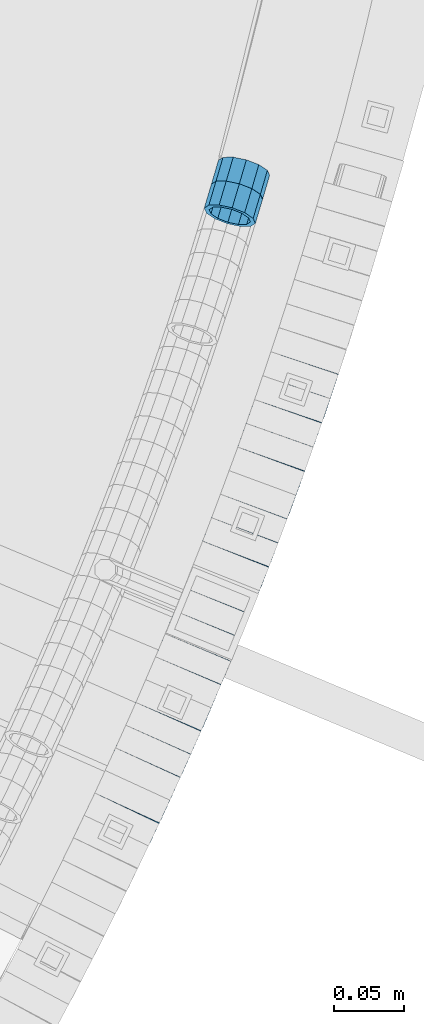
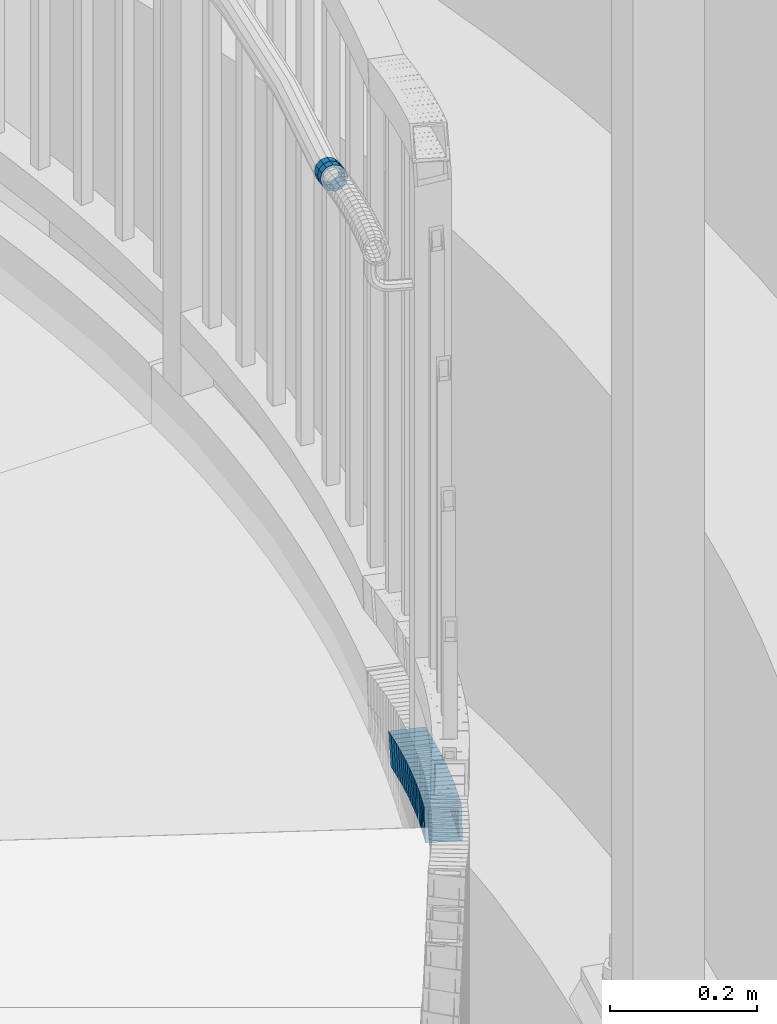
# One storey, part 798 of 975: 21 beams.
"""IFC2X3 building model written with IfcOpenShell, lengths in millimetres."""

from ifc_helpers import new_model, si_unit, frame, origin_with_axes, place, context, subcontext, project, spatial, faceted_brep, material, type_object, element, save


model = new_model("IFC2X3")

# Units and contexts
model_context = context("Model", 3, precision=1e-05, world=origin_with_axes())
body_context = subcontext(model_context, "Body", "Model", "MODEL_VIEW")
ifc_project = project(units=[si_unit("LENGTHUNIT", "METRE", prefix="MILLI"), si_unit("AREAUNIT", "SQUARE_METRE"), si_unit("VOLUMEUNIT", "CUBIC_METRE"), si_unit("MASSUNIT", "GRAM", prefix="KILO"), si_unit("TIMEUNIT", "SECOND"), si_unit("PLANEANGLEUNIT", "RADIAN"), si_unit("SOLIDANGLEUNIT", "STERADIAN"), si_unit("THERMODYNAMICTEMPERATUREUNIT", "DEGREE_CELSIUS"), si_unit("LUMINOUSINTENSITYUNIT", "LUMEN")], contexts=[model_context])

# Site, building, storey
site_placement = place(None, origin_with_axes())
site = spatial("IfcSite", under=ifc_project, at=site_placement, CompositionType="ELEMENT")
building_placement = place(site_placement, origin_with_axes())
building = spatial("IfcBuilding", under=site, at=building_placement, Name="Undefined", CompositionType="ELEMENT")
storey_placement = place(building_placement, origin_with_axes())
storey = spatial("IfcBuildingStorey", under=building, at=storey_placement, Name="Undefined", CompositionType="ELEMENT", Elevation=0.0)

# Beams
ifc_material = material()
beam_type_1 = type_object("IfcBeamType", PredefinedType="NOTDEFINED")
beam_1_placement = place(storey_placement, frame((37404.7874322749, 2603.67660607196, 3041.61300755579), z_axis=(-0.958287760646571, 0.285805122058686, -5.19926288689022e-11), x_axis=(0.271357223015151, 0.909844805051272, -0.313923061017693)))
element("IfcBeam", 1, at=beam_1_placement, inside=storey, type_object=beam_type_1, material=ifc_material, Name="WALL", context=body_context, shape_type="Brep", body=[
    faceted_brep([(-2.1246523829177e-07, -15.367000000002, 0.0), (-1.83998054126278e-07, -13.3082123799541, 7.68350000000009), (18.7944140637574, -13.3082123799568, 7.68350000002101), (18.7944140637537, -15.3669999999993, 2.91038304567337e-11), (-1.06232619145885e-07, -7.68349999999919, 13.3082123799559), (18.7944140637646, -7.68350000000282, 13.3082123799613), (-3.63797880709171e-12, 3.63797880709171e-12, 15.3670000000002), (18.7944140637646, -4.54747350886464e-12, 15.3669999999984), (1.06225343188271e-07, 7.68350000000646, 13.3082123799559), (18.7944140637683, 7.68349999999828, 13.3082123799613), (1.8399441614747e-07, 13.308212379965, 7.68350000000009), (18.7944140637665, 13.308212379955, 7.68350000001374), (2.12461600312963e-07, 15.3670000000093, 0.0), (18.7944140637592, 15.3670000000029, 2.91038304567337e-11), (1.8399441614747e-07, 13.308212379965, -7.68350000000009), (18.7944140637555, 13.3082123799613, -7.68349999995553), (1.06225343188271e-07, 7.68350000000646, -13.3082123799559), (18.7944140637519, 7.68350000000737, -13.3082123798958), (-3.63797880709171e-12, 3.63797880709171e-12, -15.3670000000002), (18.7944140637483, 6.3664629124105e-12, -15.3669999999474), (-1.06232619145885e-07, -7.68349999999919, -13.3082123799559), (18.7944140637501, -7.68349999999464, -13.3082123798958), (-1.83998054126278e-07, -13.3082123799541, -7.68350000000009), (18.7944140637483, -13.3082123799513, -7.68349999994098), (-2.63386027654633e-07, -19.0500000000029, 0.0), (-2.28097633225843e-07, -16.4977839420972, -9.52499999999964), (18.7944140637483, -16.497783942089, -9.52499999994325), (18.7944140637537, -19.0499999999984, 4.36557456851006e-11), (-1.31691194837913e-07, -9.52500000000146, -16.4977839420935), (18.7944140637483, -9.52499999999327, -16.4977839420244), (-3.63797880709171e-12, 3.63797880709171e-12, -19.0500000000002), (18.7944140637446, 8.18545231595635e-12, -19.0499999999302), (1.31687556859106e-07, 9.52500000000509, -16.4977839420935), (18.7944140637519, 9.52500000000873, -16.4977839420244), (2.28097633225843e-07, 16.4977839421044, -9.52499999999964), (18.7944140637555, 16.4977839420999, -9.52499999996508), (2.63382389675826e-07, 19.0500000000138, 0.0), (18.794414063761, 19.0500000000029, 2.91038304567337e-11), (2.28097633225843e-07, 16.4977839421044, 9.52499999999964), (18.7944140637665, 16.4977839420935, 9.52500000000873), (1.31687556859106e-07, 9.52500000000509, 16.4977839420935), (18.7944140637701, 9.524999999996, 16.4977839420899), (-3.63797880709171e-12, 3.63797880709171e-12, 19.0500000000002), (18.7944140637701, -5.45696821063757e-12, 19.0499999999884), (-1.31691194837913e-07, -9.52500000000146, 16.4977839420935), (18.7944140637665, -9.52500000000418, 16.4977839420972), (-2.28097633225843e-07, -16.4977839420972, 9.52499999999964), (18.7944140637574, -16.4977839420962, 9.52500000001601)], [[[0, 1, 2, 3]], [[1, 4, 5, 2]], [[4, 6, 7, 5]], [[6, 8, 9, 7]], [[8, 10, 11, 9]], [[10, 12, 13, 11]], [[12, 14, 15, 13]], [[14, 16, 17, 15]], [[16, 18, 19, 17]], [[18, 20, 21, 19]], [[20, 22, 23, 21]], [[22, 0, 3, 23]], [[24, 25, 26, 27]], [[25, 28, 29, 26]], [[28, 30, 31, 29]], [[30, 32, 33, 31]], [[32, 34, 35, 33]], [[34, 36, 37, 35]], [[36, 38, 39, 37]], [[38, 40, 41, 39]], [[40, 42, 43, 41]], [[42, 44, 45, 43]], [[44, 46, 47, 45]], [[46, 24, 27, 47]], [[29, 31, 33, 35, 37, 39, 41, 43, 45, 47, 27, 26], [5, 7, 9, 11, 13, 15, 17, 19, 21, 23, 3, 2]], [[46, 44, 42, 40, 38, 36, 34, 32, 30, 28, 25, 24], [22, 20, 18, 16, 14, 12, 10, 8, 6, 4, 1, 0]]]),
])
beam_2_placement = place(storey_placement, frame((37409.9416131534, 2620.84728896929, 3035.68573183975), z_axis=(-0.959811187688657, 0.280646546366937, -1.43101260619006e-10), x_axis=(0.266861250050846, 0.912665474173317, -0.30955905005878)))
element("IfcBeam", 2, at=beam_2_placement, inside=storey, type_object=beam_type_1, material=ifc_material, Name="WALL", context=body_context, shape_type="Brep", body=[
    faceted_brep([(-2.1246523829177e-07, -15.367000000002, 0.0), (-1.83998054126278e-07, -13.3082123799541, 7.68350000000009), (18.7395304103302, -13.3082123799504, 7.68350000005739), (18.7395304103338, -15.3669999999975, 4.36557456851006e-11), (-1.06232619145885e-07, -7.68349999999919, 13.3082123799559), (18.7395304103266, -7.68349999999191, 13.3082123800268), (-3.63797880709171e-12, 3.63797880709171e-12, 15.3670000000002), (18.7395304103284, 9.09494701772928e-12, 15.3670000000566), (1.06225343188271e-07, 7.68350000000646, 13.3082123799559), (18.7395304103284, 7.68350000000828, 13.308212380005), (1.8399441614747e-07, 13.308212379965, 7.68350000000009), (18.7395304103375, 13.3082123799613, 7.68350000002829), (2.12461600312963e-07, 15.3670000000093, 0.0), (18.7395304103429, 15.3670000000038, 1.45519152283669e-11), (1.8399441614747e-07, 13.308212379965, -7.68350000000009), (18.7395304103466, 13.3082123799559, -7.68350000000646), (1.06225343188271e-07, 7.68350000000646, -13.3082123799559), (18.7395304103484, 7.68349999999737, -13.3082123799686), (-3.63797880709171e-12, 3.63797880709171e-12, -15.3670000000002), (18.7395304103484, -3.63797880709171e-12, -15.3670000000129), (-1.06232619145885e-07, -7.68349999999919, -13.3082123799559), (18.7395304103466, -7.68350000000282, -13.3082123799541), (-1.83998054126278e-07, -13.3082123799541, -7.68350000000009), (18.7395304103411, -13.3082123799568, -7.68349999998463), (-2.63386027654633e-07, -19.0500000000029, 0.0), (-2.28097633225843e-07, -16.4977839420972, -9.52499999999964), (18.7395304103411, -16.4977839420953, -9.52499999997963), (18.7395304103356, -19.0499999999993, 4.36557456851006e-11), (-1.31691194837913e-07, -9.52500000000146, -16.4977839420935), (18.7395304103484, -9.52500000000509, -16.4977839420972), (-3.63797880709171e-12, 3.63797880709171e-12, -19.0500000000002), (18.7395304103557, -5.45696821063757e-12, -19.0500000000247), (1.31687556859106e-07, 9.52500000000509, -16.4977839420935), (18.739530410352, 9.52499999999691, -16.4977839421117), (2.28097633225843e-07, 16.4977839421044, -9.52499999999964), (18.7395304103484, 16.4977839420935, -9.52500000000146), (2.63382389675826e-07, 19.0500000000138, 0.0), (18.7395304103429, 19.0500000000029, 1.45519152283669e-11), (2.28097633225843e-07, 16.4977839421044, 9.52499999999964), (18.7395304103338, 16.4977839421008, 9.52500000003783), (1.31687556859106e-07, 9.52500000000509, 16.4977839420935), (18.7395304103302, 9.52500000000873, 16.4977839421481), (-3.63797880709171e-12, 3.63797880709171e-12, 19.0500000000002), (18.7395304103247, 1.09139364212751e-11, 19.0500000000684), (-1.31691194837913e-07, -9.52500000000146, 16.4977839420935), (18.7395304103247, -9.52499999999054, 16.4977839421699), (-2.28097633225843e-07, -16.4977839420972, 9.52499999999964), (18.7395304103284, -16.4977839420881, 9.52500000006694)], [[[0, 1, 2, 3]], [[1, 4, 5, 2]], [[4, 6, 7, 5]], [[6, 8, 9, 7]], [[8, 10, 11, 9]], [[10, 12, 13, 11]], [[12, 14, 15, 13]], [[14, 16, 17, 15]], [[16, 18, 19, 17]], [[18, 20, 21, 19]], [[20, 22, 23, 21]], [[22, 0, 3, 23]], [[24, 25, 26, 27]], [[25, 28, 29, 26]], [[28, 30, 31, 29]], [[30, 32, 33, 31]], [[32, 34, 35, 33]], [[34, 36, 37, 35]], [[36, 38, 39, 37]], [[38, 40, 41, 39]], [[40, 42, 43, 41]], [[42, 44, 45, 43]], [[44, 46, 47, 45]], [[46, 24, 27, 47]], [[29, 31, 33, 35, 37, 39, 41, 43, 45, 47, 27, 26], [5, 7, 9, 11, 13, 15, 17, 19, 21, 23, 3, 2]], [[46, 44, 42, 40, 38, 36, 34, 32, 30, 28, 25, 24], [22, 20, 18, 16, 14, 12, 10, 8, 6, 4, 1, 0]]]),
])
beam_type_2 = type_object("IfcBeamType", Name="HSS2X2X.188_TUBES", PredefinedType="NOTDEFINED")
beam_3_placement = place(storey_placement, frame((37328.2121095674, 2174.11265486473, 2258.91492460715), z_axis=(-0.906470607423007, 0.422268916542721, 1.90350419870811e-10), x_axis=(0.402071086044602, 0.863112598095702, -0.305574025033873)))
element("IfcBeam", 3, at=beam_3_placement, inside=storey, type_object=beam_type_2, material=ifc_material, Name="WALL", ObjectType="HSS2X2X.188_TUBES", context=body_context, shape_type="Brep", body=[
    faceted_brep([(0.0, 20.6374999999753, -20.6375000000298), (0.0, -20.6375000000153, -20.6375000000153), (18.6531498680506, -20.6374999999862, -20.6375000000007), (18.6531498680579, 20.637500000008, -20.6374999999935), (0.0, -20.6374999999825, 20.6375000000335), (18.6531498680379, -20.6374999999971, 20.6374999999789), (0.0, 20.6375000000116, 20.6375000000189), (18.6531498680451, 20.6374999999989, 20.6374999999898), (0.0, 25.3999999999724, -25.4000000000342), (0.0, 25.400000000016, 25.4000000000196), (18.653149868047, 25.399999999996, 25.3999999999869), (18.6531498680633, 25.4000000000087, -25.3999999999905), (0.0, -25.399999999976, 25.4000000000378), (18.6531498680361, -25.3999999999978, 25.3999999999796), (0.0, -25.400000000016, -25.4000000000196), (18.6531498680488, -25.3999999999851, -25.4000000000015)], [[[0, 1, 2, 3]], [[1, 4, 5, 2]], [[4, 6, 7, 5]], [[6, 0, 3, 7]], [[8, 9, 10, 11]], [[9, 12, 13, 10]], [[12, 14, 15, 13]], [[14, 8, 11, 15]], [[13, 15, 11, 10], [5, 7, 3, 2]], [[14, 12, 9, 8], [6, 4, 1, 0]]]),
])
for number, where, z_axis, x_axis, name in (
    (4, (37335.8795019804, 2190.38584330702, 2253.22561279411), (-0.91075353403974, 0.412950360496421, -1.40489646582865e-10), (0.393024484845579, 0.866807424659578, -0.306882131879483), "WALL"),
    (5, (37343.1795019804, 2206.48584330701, 2247.52561279411), (-0.91075353403974, 0.412950360496421, -1.40489646582865e-10), (0.393024484845579, 0.866807424659578, -0.306882131879483), "WALL"),
):
    element("IfcBeam", number, at=place(storey_placement, frame(where, z_axis=z_axis, x_axis=x_axis)), inside=storey, type_object=beam_type_2, material=ifc_material, Name=name, ObjectType="HSS2X2X.188_TUBES", context=body_context, shape_type="Brep", body=[
        faceted_brep([(0.0, 20.6374999999753, -20.6375000000298), (0.0, -20.6375000000153, -20.6375000000153), (18.5674446276062, -20.6375000000025, -20.6374999999898), (18.5674446275571, 20.6375000000053, -20.6374999999025), (0.0, -20.6374999999825, 20.6375000000335), (18.5674446276444, -20.6375000000135, 20.6374999999098), (0.0, 20.6375000000116, 20.6375000000189), (18.5674446275953, 20.6374999999953, 20.6374999999971), (0.0, 25.3999999999724, -25.4000000000342), (0.0, 25.400000000016, 25.4000000000196), (18.5674446275916, 25.399999999996, 25.4000000000087), (18.567444627548, 25.4000000000069, -25.399999999885), (0.0, -25.399999999976, 25.4000000000378), (18.5674446276571, -25.400000000016, 25.399999999885), (0.0, -25.400000000016, -25.4000000000196), (18.5674446276043, -25.4000000000015, -25.3999999999942)], [[[0, 1, 2, 3]], [[1, 4, 5, 2]], [[4, 6, 7, 5]], [[6, 0, 3, 7]], [[8, 9, 10, 11]], [[9, 12, 13, 10]], [[12, 14, 15, 13]], [[14, 8, 11, 15]], [[13, 15, 11, 10], [5, 7, 3, 2]], [[14, 12, 9, 8], [6, 4, 1, 0]]]),
    ])
beam_4_placement = place(storey_placement, frame((37350.7225653995, 2222.94511412158, 2241.76841417241), z_axis=(-0.914734844261663, 0.404054655577177, -1.32694367493968e-10), x_axis=(0.385467916100072, 0.872656531226467, -0.299808379077801)))
element("IfcBeam", 6, at=beam_4_placement, inside=storey, type_object=beam_type_2, material=ifc_material, Name="WALL", ObjectType="HSS2X2X.188_TUBES", context=body_context, shape_type="Brep", body=[
    faceted_brep([(0.0, 20.6374999999753, -20.6375000000298), (0.0, -20.6375000000153, -20.6375000000153), (18.677794302308, -20.6374999999989, -20.6374999999862), (18.6777943022862, 20.6375000000098, -20.6375000000153), (0.0, -20.6374999999825, 20.6375000000335), (18.6777943022862, -20.6375000000044, 20.6374999999862), (0.0, 20.6375000000116, 20.6375000000189), (18.6777943022644, 20.6375000000044, 20.6374999999571), (0.0, 25.3999999999724, -25.4000000000342), (0.0, 25.400000000016, 25.4000000000196), (18.6777943022607, 25.4000000000033, 25.3999999999505), (18.6777943022898, 25.4000000000124, -25.400000000016), (0.0, -25.399999999976, 25.4000000000378), (18.6777943022862, -25.4000000000069, 25.3999999999905), (0.0, -25.400000000016, -25.4000000000196), (18.6777943023117, -25.3999999999978, -25.3999999999796)], [[[0, 1, 2, 3]], [[1, 4, 5, 2]], [[4, 6, 7, 5]], [[6, 0, 3, 7]], [[8, 9, 10, 11]], [[9, 12, 13, 10]], [[12, 14, 15, 13]], [[14, 8, 11, 15]], [[13, 15, 11, 10], [5, 7, 3, 2]], [[14, 12, 9, 8], [6, 4, 1, 0]]]),
])
beam_5_placement = place(storey_placement, frame((37357.9016878469, 2239.14244107174, 2236.22433918873), z_axis=(-0.915897629319077, 0.401411923848427, 8.601318768342e-11), x_axis=(0.382062933802441, 0.8717492295492, -0.306726580841385)))
element("IfcBeam", 7, at=beam_5_placement, inside=storey, type_object=beam_type_2, material=ifc_material, Name="WALL", ObjectType="HSS2X2X.188_TUBES", context=body_context, shape_type="Brep", body=[
    faceted_brep([(0.0, 20.6374999999753, -20.6375000000298), (0.0, -20.6375000000153, -20.6375000000153), (18.5779439120561, -20.6375000000007, -20.6375000000116), (18.5779439120888, 20.637499999988, -20.637499999968), (0.0, -20.6374999999825, 20.6375000000335), (18.5779439120852, -20.6375000000025, 20.6375000000262), (0.0, 20.6375000000116, 20.6375000000189), (18.5779439121179, 20.6374999999862, 20.6375000000662), (0.0, 25.3999999999724, -25.4000000000342), (0.0, 25.400000000016, 25.4000000000196), (18.5779439121252, 25.3999999999851, 25.4000000000706), (18.5779439120888, 25.3999999999869, -25.3999999999687), (0.0, -25.399999999976, 25.4000000000378), (18.5779439120852, -25.4000000000015, 25.4000000000269), (0.0, -25.400000000016, -25.4000000000196), (18.5779439120524, -25.3999999999996, -25.400000000016)], [[[0, 1, 2, 3]], [[1, 4, 5, 2]], [[4, 6, 7, 5]], [[6, 0, 3, 7]], [[8, 9, 10, 11]], [[9, 12, 13, 10]], [[12, 14, 15, 13]], [[14, 8, 11, 15]], [[13, 15, 11, 10], [5, 7, 3, 2]], [[14, 12, 9, 8], [6, 4, 1, 0]]]),
])
for number, where, z_axis, x_axis, name in (
    (8, (37365.2722594875, 2255.68088064717, 2230.51096447023), (-0.921741136095342, 0.387805722017697, 6.61975718685427e-12), (0.36931678700073, 0.877796421001803, -0.305087781000619), "WALL"),
    (9, (37372.1722594875, 2272.08088064716, 2224.81096447023), (-0.921741136095342, 0.387805722017697, 6.61975718685427e-12), (0.36931678700073, 0.877796421001803, -0.305087781000619), "WALL"),
):
    element("IfcBeam", number, at=place(storey_placement, frame(where, z_axis=z_axis, x_axis=x_axis)), inside=storey, type_object=beam_type_2, material=ifc_material, Name=name, ObjectType="HSS2X2X.188_TUBES", context=body_context, shape_type="Brep", body=[
        faceted_brep([(0.0, 20.6374999999753, -20.6375000000298), (0.0, -20.6375000000153, -20.6375000000153), (18.677794302308, -20.6374999999989, -20.6374999999862), (18.6777943022862, 20.6375000000098, -20.6375000000153), (0.0, -20.6374999999825, 20.6375000000335), (18.6777943022862, -20.6375000000044, 20.6374999999862), (0.0, 20.6375000000116, 20.6375000000189), (18.6777943022644, 20.6375000000044, 20.6374999999571), (0.0, 25.3999999999724, -25.4000000000342), (0.0, 25.400000000016, 25.4000000000196), (18.6777943022607, 25.4000000000033, 25.3999999999505), (18.6777943022898, 25.4000000000124, -25.400000000016), (0.0, -25.399999999976, 25.4000000000378), (18.6777943022862, -25.4000000000069, 25.3999999999905), (0.0, -25.400000000016, -25.4000000000196), (18.6777943023117, -25.3999999999978, -25.3999999999796)], [[[0, 1, 2, 3]], [[1, 4, 5, 2]], [[4, 6, 7, 5]], [[6, 0, 3, 7]], [[8, 9, 10, 11]], [[9, 12, 13, 10]], [[12, 14, 15, 13]], [[14, 8, 11, 15]], [[13, 15, 11, 10], [5, 7, 3, 2]], [[14, 12, 9, 8], [6, 4, 1, 0]]]),
    ])
beam_6_placement = place(storey_placement, frame((37379.1543667581, 2288.57296936397, 2219.11585595598), z_axis=(-0.923742113528485, 0.383015022804495, 0.0), x_axis=(0.364680727927909, 0.879524107826065, -0.305688256939542)))
element("IfcBeam", 10, at=beam_6_placement, inside=storey, type_object=beam_type_2, material=ifc_material, Name="WALL", ObjectType="HSS2X2X.188_TUBES", context=body_context, shape_type="Brep", body=[
    faceted_brep([(0.0, 20.6374999999753, -20.6375000000298), (0.0, -20.6375000000153, -20.6375000000153), (18.6531498680506, -20.6374999999862, -20.6375000000007), (18.6531498680579, 20.637500000008, -20.6374999999935), (0.0, -20.6374999999825, 20.6375000000335), (18.6531498680379, -20.6374999999971, 20.6374999999789), (0.0, 20.6375000000116, 20.6375000000189), (18.6531498680451, 20.6374999999989, 20.6374999999898), (0.0, 25.3999999999724, -25.4000000000342), (0.0, 25.400000000016, 25.4000000000196), (18.653149868047, 25.399999999996, 25.3999999999869), (18.6531498680633, 25.4000000000087, -25.3999999999905), (0.0, -25.399999999976, 25.4000000000378), (18.6531498680361, -25.3999999999978, 25.3999999999796), (0.0, -25.400000000016, -25.4000000000196), (18.6531498680488, -25.3999999999851, -25.4000000000015)], [[[0, 1, 2, 3]], [[1, 4, 5, 2]], [[4, 6, 7, 5]], [[6, 0, 3, 7]], [[8, 9, 10, 11]], [[9, 12, 13, 10]], [[12, 14, 15, 13]], [[14, 8, 11, 15]], [[13, 15, 11, 10], [5, 7, 3, 2]], [[14, 12, 9, 8], [6, 4, 1, 0]]]),
])
beam_7_placement = place(storey_placement, frame((37386.0397038646, 2305.0298731144, 2213.44862754448), z_axis=(-0.926527754315015, 0.376226421831289, 8.95097400643863e-11), x_axis=(0.357731670964824, 0.880980979913068, -0.309678162969438)))
element("IfcBeam", 11, at=beam_7_placement, inside=storey, type_object=beam_type_2, material=ifc_material, Name="WALL", ObjectType="HSS2X2X.188_TUBES", context=body_context, shape_type="Brep", body=[
    faceted_brep([(0.0, 20.6374999999753, -20.6375000000298), (0.0, -20.6375000000153, -20.6375000000153), (18.7347271129966, -20.6375000000116, -20.6375000000262), (18.7347271130257, 20.6374999999989, -20.6374999999935), (0.0, -20.6374999999825, 20.6375000000335), (18.7347271129947, -20.6375000000116, 20.6374999999607), (0.0, 20.6375000000116, 20.6375000000189), (18.7347271130147, 20.6375000000007, 20.6374999999898), (0.0, 25.3999999999724, -25.4000000000342), (0.0, 25.400000000016, 25.4000000000196), (18.7347271130166, 25.4000000000015, 25.3999999999905), (18.7347271130257, 25.3999999999996, -25.3999999999869), (0.0, -25.399999999976, 25.4000000000378), (18.7347271129875, -25.4000000000106, 25.3999999999505), (0.0, -25.400000000016, -25.4000000000196), (18.7347271130002, -25.4000000000124, -25.4000000000233)], [[[0, 1, 2, 3]], [[1, 4, 5, 2]], [[4, 6, 7, 5]], [[6, 0, 3, 7]], [[8, 9, 10, 11]], [[9, 12, 13, 10]], [[12, 14, 15, 13]], [[14, 8, 11, 15]], [[13, 15, 11, 10], [5, 7, 3, 2]], [[14, 12, 9, 8], [6, 4, 1, 0]]]),
])
beam_8_placement = place(storey_placement, frame((37392.8346851654, 2321.7208809138, 2207.59732250594), z_axis=(-0.92731642037397, 0.374278314232614, -2.41170710069127e-11), x_axis=(0.356635328114076, 0.883603947282888, -0.303406175097121)))
element("IfcBeam", 12, at=beam_8_placement, inside=storey, type_object=beam_type_2, material=ifc_material, Name="WALL", ObjectType="HSS2X2X.188_TUBES", context=body_context, shape_type="Brep", body=[
    faceted_brep([(0.0, 20.6374999999753, -20.6375000000298), (0.0, -20.6375000000153, -20.6375000000153), (18.7853666454903, -20.6375000000535, -20.6375000000326), (18.785366645363, 20.6374999999862, -20.6375000000044), (0.0, -20.6374999999825, 20.6375000000335), (18.785366645352, -20.6375000000007, 20.6374999999989), (0.0, 20.6375000000116, 20.6375000000189), (18.7853666453102, 20.6375000000025, 20.6374999999753), (0.0, 25.3999999999724, -25.4000000000342), (0.0, 25.400000000016, 25.4000000000196), (18.7853666452065, 25.4000000000451, 25.4000000000351), (18.7853666453739, 25.3999999999833, -25.400000000006), (0.0, -25.399999999976, 25.4000000000378), (18.7853666497213, -25.399999993424, 25.3999999995158), (0.0, -25.400000000016, -25.4000000000196), (18.7853666455194, -25.4000000000633, -25.4000000000406)], [[[0, 1, 2, 3]], [[1, 4, 5, 2]], [[4, 6, 7, 5]], [[6, 0, 3, 7]], [[8, 9, 10, 11]], [[9, 12, 13, 10]], [[12, 14, 15, 13]], [[14, 8, 11, 15]], [[13, 15, 11, 10], [5, 7, 3, 2]], [[14, 12, 9, 8], [6, 4, 1, 0]]]),
])
beam_9_placement = place(storey_placement, frame((37399.6962461725, 2338.50982432888, 2201.90657097033), z_axis=(-0.93115999424701, 0.364610840642332, 1.35282334667863e-10), x_axis=(0.347290807062255, 0.886927293158988, -0.304547323054592)))
element("IfcBeam", 13, at=beam_9_placement, inside=storey, type_object=beam_type_2, material=ifc_material, Name="WALL", ObjectType="HSS2X2X.188_TUBES", context=body_context, shape_type="Brep", body=[
    faceted_brep([(0.0, 20.6374999999753, -20.6375000000298), (0.0, -20.6375000000153, -20.6375000000153), (18.724849799155, -20.6375000000171, -20.6374999999425), (18.7248497991204, 20.6374999999989, -20.6375000000007), (0.0, -20.6374999999825, 20.6375000000335), (18.7248497991168, -20.6374999999953, 20.6375000000007), (0.0, 20.6375000000116, 20.6375000000189), (18.724849799084, 20.6375000000226, 20.6374999999498), (0.0, 25.3999999999724, -25.4000000000342), (0.0, 25.400000000016, 25.4000000000196), (18.7248497990731, 25.4000000000269, 25.399999999936), (18.7248497991204, 25.3999999999978, -25.3999999999978), (0.0, -25.399999999976, 25.4000000000378), (18.7248497991186, -25.3999999999942, 25.4000000000051), (0.0, -25.400000000016, -25.4000000000196), (18.7248497991604, -25.4000000000233, -25.3999999999323)], [[[0, 1, 2, 3]], [[1, 4, 5, 2]], [[4, 6, 7, 5]], [[6, 0, 3, 7]], [[8, 9, 10, 11]], [[9, 12, 13, 10]], [[12, 14, 15, 13]], [[14, 8, 11, 15]], [[13, 15, 11, 10], [5, 7, 3, 2]], [[14, 12, 9, 8], [6, 4, 1, 0]]]),
])
for number, where, z_axis, x_axis, name in (
    (14, (37406.3230117666, 2355.28212408451, 2196.19941195074), (-0.933777260465072, 0.357854758021108, 4.67603058496023e-11), (0.340956519010263, 0.889683418026619, -0.303664400009085), "WALL"),
    (15, (37412.7597230481, 2371.96413118765, 2190.54339132083), (-0.935636632330691, 0.35296471812475, 0.0), (0.335686242946026, 0.889834960856945, -0.309044476950326), "WALL"),
):
    element("IfcBeam", number, at=place(storey_placement, frame(where, z_axis=z_axis, x_axis=x_axis)), inside=storey, type_object=beam_type_2, material=ifc_material, Name=name, ObjectType="HSS2X2X.188_TUBES", context=body_context, shape_type="Brep", body=[
        faceted_brep([(0.0, 20.6374999999753, -20.6375000000298), (0.0, -20.6375000000153, -20.6375000000153), (18.767258723612, -20.6375000000025, -20.6374999999862), (18.7672587236229, 20.6374999999953, -20.637499999968), (0.0, -20.6374999999825, 20.6375000000335), (18.767258723612, -20.6375000000135, 20.6375000000153), (0.0, 20.6375000000116, 20.6375000000189), (18.7672587236266, 20.6374999999844, 20.6375000000371), (0.0, 25.3999999999724, -25.4000000000342), (0.0, 25.400000000016, 25.4000000000196), (18.7672587236302, 25.3999999999814, 25.4000000000342), (18.7672587236229, 25.399999999996, -25.3999999999687), (0.0, -25.399999999976, 25.4000000000378), (18.7672587236157, -25.4000000000142, 25.400000000016), (0.0, -25.400000000016, -25.4000000000196), (18.767258723612, -25.4000000000015, -25.3999999999905)], [[[0, 1, 2, 3]], [[1, 4, 5, 2]], [[4, 6, 7, 5]], [[6, 0, 3, 7]], [[8, 9, 10, 11]], [[9, 12, 13, 10]], [[12, 14, 15, 13]], [[14, 8, 11, 15]], [[13, 15, 11, 10], [5, 7, 3, 2]], [[14, 12, 9, 8], [6, 4, 1, 0]]]),
    ])
beam_10_placement = place(storey_placement, frame((37419.1477083037, 2388.85463955262, 2184.69219955276), z_axis=(-0.936329177550236, 0.351123441638549, 1.68892256624531e-10), x_axis=(0.334642764084973, 0.892380704226827, -0.302772025076958)))
element("IfcBeam", 16, at=beam_10_placement, inside=storey, type_object=beam_type_2, material=ifc_material, Name="WALL", ObjectType="HSS2X2X.188_TUBES", context=body_context, shape_type="Brep", body=[
    faceted_brep([(0.0, 20.6374999999753, -20.6375000000298), (0.0, -20.6375000000153, -20.6375000000153), (18.8332159191086, -20.6374999999916, -20.6375000000153), (18.8332159190923, 20.6375000000062, -20.6375000000335), (0.0, -20.6374999999825, 20.6375000000335), (18.8332159191377, -20.6375000000062, 20.6375000000335), (0.0, 20.6375000000116, 20.6375000000189), (18.8332159191141, 20.6374999999916, 20.6375000000116), (0.0, 25.3999999999724, -25.4000000000342), (0.0, 25.400000000016, 25.4000000000196), (18.8332159191159, 25.3999999999905, 25.4000000000124), (18.8332159190886, 25.4000000000069, -25.4000000000415), (0.0, -25.399999999976, 25.4000000000378), (18.8332159191395, -25.4000000000069, 25.4000000000378), (0.0, -25.400000000016, -25.4000000000196), (18.8332159191104, -25.3999999999905, -25.400000000016)], [[[0, 1, 2, 3]], [[1, 4, 5, 2]], [[4, 6, 7, 5]], [[6, 0, 3, 7]], [[8, 9, 10, 11]], [[9, 12, 13, 10]], [[12, 14, 15, 13]], [[14, 8, 11, 15]], [[13, 15, 11, 10], [5, 7, 3, 2]], [[14, 12, 9, 8], [6, 4, 1, 0]]]),
])
beam_11_placement = place(storey_placement, frame((37425.6074072816, 2405.81099647982, 2179.02822563006), z_axis=(-0.940603278300761, 0.33950769188615, 6.75308911013417e-11), x_axis=(0.323090682126602, 0.895120087350968, -0.307200977120456)))
element("IfcBeam", 17, at=beam_11_placement, inside=storey, type_object=beam_type_2, material=ifc_material, Name="WALL", ObjectType="HSS2X2X.188_TUBES", context=body_context, shape_type="Brep", body=[
    faceted_brep([(0.0, 20.6374999999753, -20.6375000000298), (0.0, -20.6375000000153, -20.6375000000153), (18.8814724002259, -20.6375000000171, -20.6374999999753), (18.8814724002277, 20.6374999999916, -20.6374999999716), (0.0, -20.6374999999825, 20.6375000000335), (18.8814724002368, -20.6375000000062, 20.6375000000298), (0.0, 20.6375000000116, 20.6375000000189), (18.8814724002386, 20.6375000000025, 20.6375000000262), (0.0, 25.3999999999724, -25.4000000000342), (0.0, 25.400000000016, 25.4000000000196), (18.8814724002386, 25.4000000000051, 25.4000000000269), (18.8814724002277, 25.3999999999905, -25.399999999976), (0.0, -25.399999999976, 25.4000000000378), (18.8814724002368, -25.4000000000051, 25.4000000000269), (0.0, -25.400000000016, -25.4000000000196), (18.8814724002259, -25.4000000000196, -25.399999999976)], [[[0, 1, 2, 3]], [[1, 4, 5, 2]], [[4, 6, 7, 5]], [[6, 0, 3, 7]], [[8, 9, 10, 11]], [[9, 12, 13, 10]], [[12, 14, 15, 13]], [[14, 8, 11, 15]], [[13, 15, 11, 10], [5, 7, 3, 2]], [[14, 12, 9, 8], [6, 4, 1, 0]]]),
])
beam_12_placement = place(storey_placement, frame((37431.8273151534, 2422.92536877335, 2173.19330349805), z_axis=(-0.942371042646175, 0.334569601102613, -6.83608050167094e-11), x_axis=(0.318851369938877, 0.898098024828015, -0.302908800941999)))
element("IfcBeam", 18, at=beam_12_placement, inside=storey, type_object=beam_type_2, material=ifc_material, Name="WALL", ObjectType="HSS2X2X.188_TUBES", context=body_context, shape_type="Brep", body=[
    faceted_brep([(0.0, 20.6374999999753, -20.6375000000298), (0.0, -20.6375000000153, -20.6375000000153), (18.8225928075335, -20.6374999999935, -20.6375000000298), (18.8225928075699, 20.6374999999898, -20.6374999999825), (0.0, -20.6374999999825, 20.6375000000335), (18.8225928075772, -20.637500000008, 20.6375000000226), (0.0, 20.6375000000116, 20.6375000000189), (18.8225928076135, 20.6374999999753, 20.6375000000698), (0.0, 25.3999999999724, -25.4000000000342), (0.0, 25.400000000016, 25.4000000000196), (18.8225928076281, 25.3999999999705, 25.4000000000815), (18.8225928075663, 25.3999999999905, -25.3999999999796), (0.0, -25.399999999976, 25.4000000000378), (18.8225928075808, -25.4000000000087, 25.4000000000233), (0.0, -25.400000000016, -25.4000000000196), (18.8225928075226, -25.3999999999905, -25.4000000000378)], [[[0, 1, 2, 3]], [[1, 4, 5, 2]], [[4, 6, 7, 5]], [[6, 0, 3, 7]], [[8, 9, 10, 11]], [[9, 12, 13, 10]], [[12, 14, 15, 13]], [[14, 8, 11, 15]], [[13, 15, 11, 10], [5, 7, 3, 2]], [[14, 12, 9, 8], [6, 4, 1, 0]]]),
])
beam_13_placement = place(storey_placement, frame((37437.8281258717, 2439.78463205578, 2167.52057137198), z_axis=(-0.94299033356188, 0.332820117794665, 1.53827386384364e-11), x_axis=(0.31682678295015, 0.897675884859024, -0.306265889951897)))
element("IfcBeam", 19, at=beam_13_placement, inside=storey, type_object=beam_type_2, material=ifc_material, Name="WALL", ObjectType="HSS2X2X.188_TUBES", context=body_context, shape_type="Brep", body=[
    faceted_brep([(0.0, 20.6374999999753, -20.6375000000298), (0.0, -20.6375000000153, -20.6375000000153), (18.9372648500248, -20.6375000000098, -20.6374999999716), (18.9372648499939, 20.637500000008, -20.6375000000189), (0.0, -20.6374999999825, 20.6375000000335), (18.9372648500175, -20.6375000000007, 20.6375000000116), (0.0, 20.6375000000116, 20.6375000000189), (18.9372648499884, 20.6375000000153, 20.6374999999643), (0.0, 25.3999999999724, -25.4000000000342), (0.0, 25.400000000016, 25.4000000000196), (18.9372648499811, 25.4000000000196, 25.3999999999578), (18.9372648499884, 25.4000000000087, -25.4000000000233), (0.0, -25.399999999976, 25.4000000000378), (18.9372648500193, -25.4000000000033, 25.400000000016), (0.0, -25.400000000016, -25.4000000000196), (18.9372648500266, -25.4000000000124, -25.3999999999651)], [[[0, 1, 2, 3]], [[1, 4, 5, 2]], [[4, 6, 7, 5]], [[6, 0, 3, 7]], [[8, 9, 10, 11]], [[9, 12, 13, 10]], [[12, 14, 15, 13]], [[14, 8, 11, 15]], [[13, 15, 11, 10], [5, 7, 3, 2]], [[14, 12, 9, 8], [6, 4, 1, 0]]]),
])
beam_14_placement = place(storey_placement, frame((37443.9063322434, 2456.88457540361, 2161.72473774109), z_axis=(-0.944721486652221, 0.32787392799309, -3.46490196534433e-11), x_axis=(0.312064496053616, 0.899168886154109, -0.306775267052579)))
element("IfcBeam", 20, at=beam_14_placement, inside=storey, type_object=beam_type_2, material=ifc_material, Name="WALL", ObjectType="HSS2X2X.188_TUBES", context=body_context, shape_type="Brep", body=[
    faceted_brep([(0.0, 20.6374999999753, -20.6375000000298), (0.0, -20.6375000000153, -20.6375000000153), (18.9092569923087, -20.6374999999971, -20.6374999999971), (18.9092569922723, 20.6375000000107, -20.6374999999098), (0.0, -20.6374999999825, 20.6375000000335), (18.9092569923087, -20.6374999999998, 20.6375000000044), (0.0, 20.6375000000116, 20.6375000000189), (18.9092569922686, 20.637500000008, 20.6375000001062), (0.0, 25.3999999999724, -25.4000000000342), (0.0, 25.400000000016, 25.4000000000196), (18.909256992265, 25.4000000000078, 25.4000000001106), (18.909256992265, 25.4000000000133, -25.3999999998996), (0.0, -25.399999999976, 25.4000000000378), (18.9092569923123, -25.4000000000024, 25.3999999999869), (0.0, -25.400000000016, -25.4000000000196), (18.9092569923123, -25.3999999999987, -25.400000000016)], [[[0, 1, 2, 3]], [[1, 4, 5, 2]], [[4, 6, 7, 5]], [[6, 0, 3, 7]], [[8, 9, 10, 11]], [[9, 12, 13, 10]], [[12, 14, 15, 13]], [[14, 8, 11, 15]], [[13, 15, 11, 10], [5, 7, 3, 2]], [[14, 12, 9, 8], [6, 4, 1, 0]]]),
])
beam_15_placement = place(storey_placement, frame((37450.0014585901, 2474.16076224876, 2155.92092039509), z_axis=(-0.948683297955354, 0.316227766302317, -9.68284439295534e-11), x_axis=(0.301027414908714, 0.9030822437265, -0.306308596907248)))
element("IfcBeam", 21, at=beam_15_placement, inside=storey, type_object=beam_type_2, material=ifc_material, Name="WALL", ObjectType="HSS2X2X.188_TUBES", context=body_context, shape_type="Brep", body=[
    faceted_brep([(0.0, 20.6374999999753, -20.6375000000298), (0.0, -20.6375000000153, -20.6375000000153), (18.9372648500248, -20.6375000000098, -20.6374999999716), (18.9372648499939, 20.637500000008, -20.6375000000189), (0.0, -20.6374999999825, 20.6375000000335), (18.9372648500175, -20.6375000000007, 20.6375000000116), (0.0, 20.6375000000116, 20.6375000000189), (18.9372648499884, 20.6375000000153, 20.6374999999643), (0.0, 25.3999999999724, -25.4000000000342), (0.0, 25.400000000016, 25.4000000000196), (18.9372648499811, 25.4000000000196, 25.3999999999578), (18.9372648499884, 25.4000000000087, -25.4000000000233), (0.0, -25.399999999976, 25.4000000000378), (18.9372648500193, -25.4000000000033, 25.400000000016), (0.0, -25.400000000016, -25.4000000000196), (18.9372648500266, -25.4000000000124, -25.3999999999651)], [[[0, 1, 2, 3]], [[1, 4, 5, 2]], [[4, 6, 7, 5]], [[6, 0, 3, 7]], [[8, 9, 10, 11]], [[9, 12, 13, 10]], [[12, 14, 15, 13]], [[14, 8, 11, 15]], [[13, 15, 11, 10], [5, 7, 3, 2]], [[14, 12, 9, 8], [6, 4, 1, 0]]]),
])

save(model, "model.ifc")
